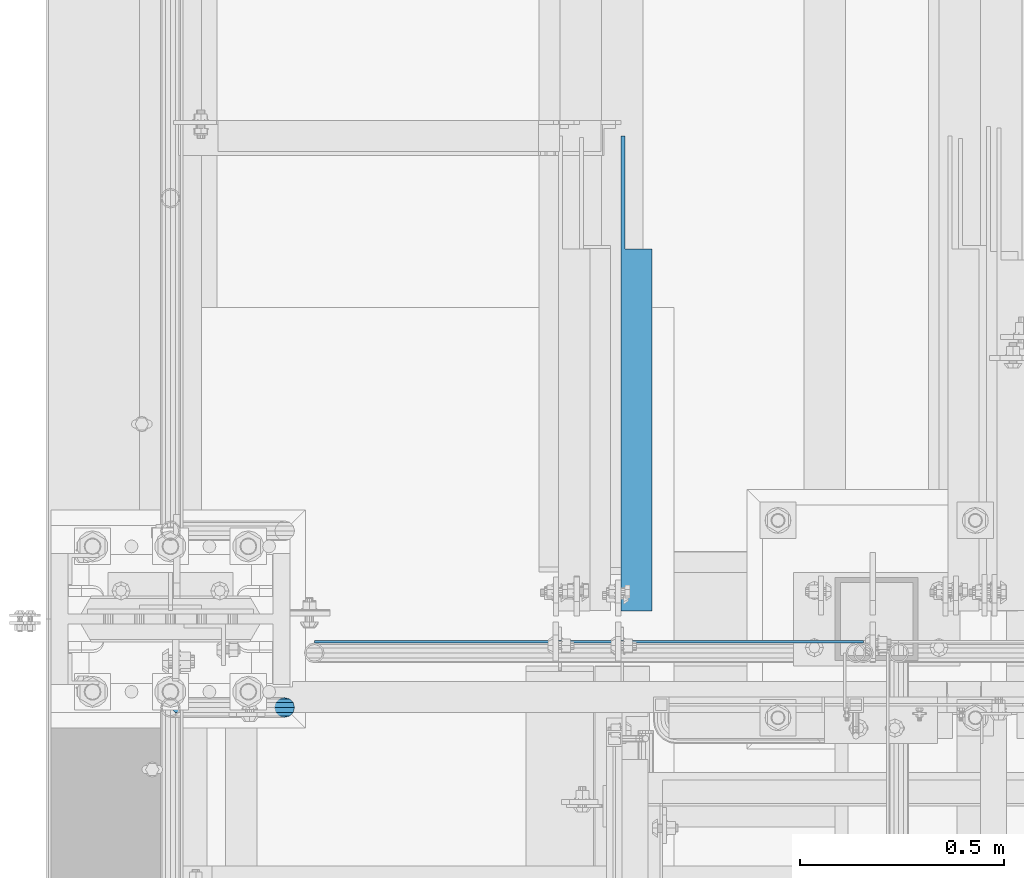
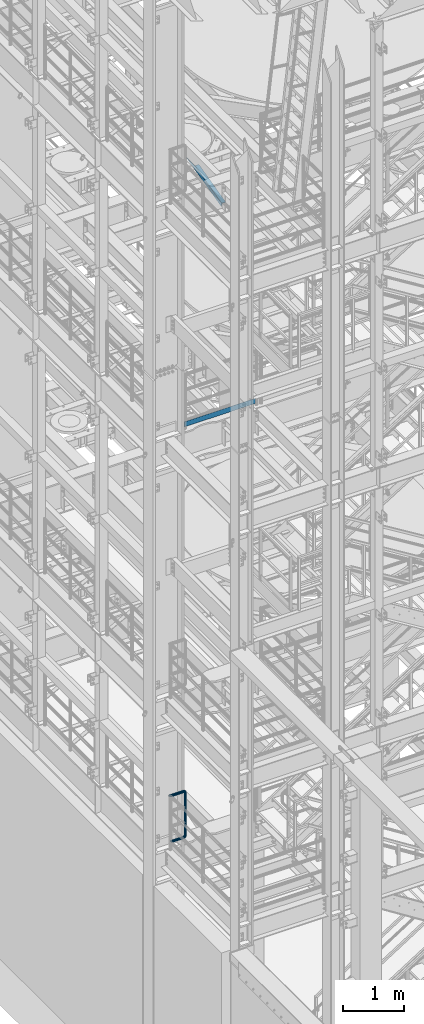
# One storey, part 962 of 1876: 3 beams, 3 elements without a shape of their own.
"""IFC2X3 building model written with IfcOpenShell, lengths in millimetres."""

from ifc_helpers import new_model, si_unit, frame, origin_with_axes, place, context, subcontext, project, spatial, faceted_brep, material, type_object, element, aggregate, save


model = new_model("IFC2X3")

# Units and contexts
model_context = context("Model", 3, precision=1e-05, world=origin_with_axes())
body_context = subcontext(model_context, "Body", "Model", "MODEL_VIEW")
ifc_project = project(units=[si_unit("LENGTHUNIT", "METRE", prefix="MILLI"), si_unit("AREAUNIT", "SQUARE_METRE"), si_unit("VOLUMEUNIT", "CUBIC_METRE"), si_unit("MASSUNIT", "GRAM", prefix="KILO"), si_unit("TIMEUNIT", "SECOND"), si_unit("PLANEANGLEUNIT", "RADIAN"), si_unit("SOLIDANGLEUNIT", "STERADIAN"), si_unit("THERMODYNAMICTEMPERATUREUNIT", "DEGREE_CELSIUS"), si_unit("LUMINOUSINTENSITYUNIT", "LUMEN")], contexts=[model_context])

# Site, building, storey
site_placement = place(None, origin_with_axes())
site = spatial("IfcSite", under=ifc_project, at=site_placement, CompositionType="ELEMENT")
building_placement = place(site_placement, origin_with_axes())
building = spatial("IfcBuilding", under=site, at=building_placement, Name="Undefined", CompositionType="ELEMENT")
storey_placement = place(building_placement, origin_with_axes())
storey = spatial("IfcBuildingStorey", under=building, at=storey_placement, Name="Undefined", CompositionType="ELEMENT", Elevation=0.0)

# Assembly, beam
assembly_1_placement = place(storey_placement, origin_with_axes())
assembly_1 = element("IfcElementAssembly", 1, at=assembly_1_placement, inside=storey, Name="RAIL", AssemblyPlace="NOTDEFINED", PredefinedType="RIGID_FRAME")
ifc_material_1 = material()
beam_type_1 = type_object("IfcBeamType", Name="PIPE1-1/2SCH40", PredefinedType="NOTDEFINED")
beam_1_placement = place(assembly_1_placement, frame((5.00222085975111e-12, -4788.2175, 6207.125), z_axis=(0.0, 0.0, 1.0), x_axis=(1.0, 0.0, 0.0)))
beam_1 = element("IfcBeam", 2, at=beam_1_placement, type_object=beam_type_1, material=ifc_material_1, Name="RAIL", ObjectType="PIPE1-1/2SCH40", context=body_context, shape_type="Brep", body=[
    faceted_brep([(1.20714750983051e-12, 24.1299999999974, -914.399963378906), (12.0650000000014, 20.8971929933159, -926.464963378905), (12.0650000000014, 20.8971929933177, -902.334963378908), (12.0650000000014, -20.8971929933195, -902.334963378908), (12.0650000000014, -20.8971929933195, -926.464963378905), (1.52133659548828e-12, -24.130000000001, -914.399963378906), (20.8971929933199, -12.0650000000023, -893.502770385589), (20.8971929933199, -12.0650000000005, -898.533841947723), (15.2545715621378, -17.7076214311819, -904.176463378906), (12.5151929933181, -20.4470000000019, -914.399963378906), (15.2545715621376, -17.7076214311819, -924.623463378906), (20.8971929933199, -12.0650000000005, -930.26608481009), (20.8971929933199, -12.0650000000023, -935.297156372224), (24.1300000000014, -1.81898940354586e-12, -934.846963378906), (24.1300000000014, -1.81898940354586e-12, -938.529963378907), (21.3906214311813, -10.2235000000019, -932.107584810088), (21.3906214311823, 10.2234999999982, -932.107584810088), (20.8971929933199, 12.0650000000005, -930.266084810086), (20.8971929933199, 12.0649999999987, -935.297156372224), (15.2545715621413, 17.7076214311783, -924.623463378906), (12.5151929933216, 20.4469999999983, -914.399963378906), (15.2545715621411, 17.7076214311783, -904.176463378906), (20.8971929933199, 12.0650000000005, -898.533841947727), (20.8971929933199, 12.0649999999987, -893.502770385589), (21.3906214311822, 10.2234999999982, -896.692341947724), (24.1300000000014, 0.0, -893.952963378906), (24.1300000000014, 0.0, -890.269963378905), (21.3906214311814, -10.2235000000019, -896.692341947724), (241.299995422363, -20.8971929933177, 12.0649999999987), (241.299995422363, -24.1299999999992, 0.0), (253.073542436527, -24.1299999999992, -1.86474665447167), (256.801832473661, -20.8971929933177, 9.60975021462946), (241.299995422363, -12.0650000000005, 20.8971929933177), (259.531130206197, -12.0650000000005, 18.0096649141014), (241.299995422363, 0.0, 24.130000000001), (260.530122510796, 0.0, 21.084247083727), (241.299995422363, 12.0650000000005, 20.8971929933177), (259.531130206197, 12.0650000000005, 18.0096649141014), (241.299995422363, 20.8971929933177, 12.0649999999987), (256.801832473661, 20.8971929933177, 9.60975021462946), (241.299995422363, 24.1299999999992, 0.0), (253.073542436527, 24.1299999999992, -1.86474665447167), (241.299995422363, 20.8971929933177, -12.0649999999987), (249.345252399393, 20.8971929933177, -13.3392435235728), (241.299995422363, 12.0650000000005, -20.8971929933177), (246.615954666858, 12.0650000000005, -21.7391582230448), (241.299995422363, 0.0, -24.130000000001), (245.616962362259, 0.0, -24.8137403926739), (241.299995422363, -12.0650000000005, -20.8971929933177), (246.615954666858, -12.0650000000005, -21.7391582230448), (241.299995422363, -20.8971929933177, -12.0649999999987), (249.345252399393, -20.8971929933177, -13.3392435235728), (267.334993896485, 20.8971929933177, -38.0999984741211), (279.399993896485, 24.1299999999992, -38.0999984741211), (279.399993896484, 24.1299999999992, -876.299964904785), (267.334993896484, 20.8971929933177, -876.299964904785), (291.464993896486, 20.8971929933177, -38.0999984741211), (291.464993896484, 20.8971929933177, -876.299964904785), (300.297186889804, 12.0650000000005, -38.0999984741211), (300.297186889803, 12.0650000000005, -876.299964904785), (303.529993896486, 0.0, -38.0999984741211), (303.529993896484, 0.0, -876.299964904785), (300.297186889804, -12.0650000000005, -38.0999984741211), (300.297186889803, -12.0650000000005, -876.299964904785), (291.464993896486, -20.8971929933177, -38.0999984741211), (291.464993896484, -20.8971929933177, -876.299964904785), (279.399993896484, -24.1299999999992, -38.0999984741211), (279.399993896484, -24.1299999999992, -876.299964904785), (267.334993896485, -20.8971929933177, -38.0999984741211), (267.334993896484, -20.8971929933177, -876.299964904785), (258.502800903167, -12.0650000000005, -38.0999984741211), (258.502800903166, -12.0650000000005, -876.299964904785), (255.269993896485, 0.0, -38.0999984741211), (255.269993896484, 0.0, -876.299964904785), (258.502800903167, 12.0650000000005, -38.0999984741211), (258.502800903166, 12.0650000000005, -876.299964904785), (257.660835673438, 12.0650000000005, -881.615924149282), (254.586253503809, 0.0, -880.616931844681), (257.660835673438, -12.0650000000005, -881.615924149282), (266.06075037291, -20.8971929933177, -884.345221881817), (277.535247242011, -24.130000000001, -888.073511918952), (289.009744111112, -20.8971929933195, -891.801801956084), (297.409658810584, -12.0650000000005, -894.531099688622), (300.484240980214, 0.0, -895.53009199322), (297.409658810584, 12.0650000000005, -894.531099688622), (289.009744111112, 20.8971929933177, -891.801801956084), (277.535247242011, 24.1299999999992, -888.073511918952), (266.06075037291, 20.8971929933177, -884.345221881817), (241.299995422364, -1.81898940354586e-12, -938.529963378911), (241.299995422364, -12.0650000000005, -935.297156372228), (241.299995422364, -20.8971929933195, -926.464963378909), (241.299995422363, -24.130000000001, -914.399963378906), (241.299995422363, -20.8971929933195, -902.334963378908), (241.299995422363, -12.0650000000005, -893.502770385589), (241.299995422363, 0.0, -890.269963378909), (241.299995422364, 20.8971929933177, -926.464963378909), (241.299995422364, 12.0649999999987, -935.297156372228), (241.299995422364, 24.1299999999992, -914.39996337891), (241.299995422363, 20.8971929933177, -902.334963378908), (241.299995422363, 12.0649999999987, -893.502770385589), (260.530122510801, 0.0, -935.484210462637), (259.531130206202, 12.0649999999987, -932.409628293008), (259.531130206201, -12.0650000000005, -932.409628293008), (256.801832473666, -20.8971929933195, -924.009713593536), (253.07354243653, -24.130000000001, -912.535216724435), (249.345252399395, -20.8971929933195, -901.060719855333), (246.615954666859, -12.0650000000005, -892.660805155861), (245.61696236226, 0.0, -889.586222986232), (246.615954666859, 12.0649999999987, -892.660805155861), (249.345252399395, 20.8971929933177, -901.060719855333), (253.07354243653, 24.1299999999992, -912.535216724435), (256.801832473666, 20.8971929933177, -924.009713593536), (275.977674493594, 12.0649999999987, -924.029695422345), (270.786241706733, 20.8971929933177, -916.884301193139), (277.877870775644, 0.0, -926.645091230272), (275.977674493608, -12.0650000000005, -924.029695422334), (270.786241706733, -20.8971929933195, -916.884301193139), (263.694612637823, -24.130000000001, -907.123511156005), (256.602983568912, -20.8971929933195, -897.362721118872), (251.411550782037, -12.0650000000005, -890.21732688968), (249.511354500001, 0.0, -887.601931081743), (251.411550782037, 12.0650000000005, -890.21732688968), (256.602983568912, 20.8971929933177, -897.362721118872), (263.694612637823, 24.1299999999992, -907.123511156005), (281.884331710718, 20.8971929933177, -905.786211189152), (272.123541673585, 24.1299999999992, -898.694582120243), (289.029725939912, 12.0650000000005, -910.977643976028), (291.645121747852, 0.0, -912.877840258065), (289.029725939912, -12.0650000000005, -910.977643976028), (281.884331710718, -20.8971929933195, -905.786211189152), (272.123541673585, -24.130000000001, -898.694582120243), (262.362751636451, -20.8971929933195, -891.602953051333), (255.217357407258, -12.0650000000005, -886.411520264461), (252.601961599318, 0.0, -884.511323982424), (255.217357407258, 12.0650000000005, -886.411520264461), (262.362751636451, 20.8971929933177, -891.602953051333), (266.060750372911, 20.8971929933177, -30.0547414970897), (257.660835673439, 12.0650000000005, -32.7840392296275), (277.535247242011, 24.1299999999992, -26.3264514599541), (289.009744111112, 20.8971929933177, -22.5981614228222), (297.409658810584, 12.0650000000005, -19.8688636902843), (300.484240980213, 0.0, -18.8698713856866), (297.409658810584, -12.0650000000005, -19.8688636902843), (289.009744111112, -20.8971929933177, -22.5981614228222), (277.535247242011, -24.1299999999992, -26.3264514599541), (266.060750372911, -20.8971929933177, -30.0547414970897), (257.660835673439, -12.0650000000005, -32.7840392296275), (254.58625350381, 0.0, -33.7830315342253), (255.217357407257, 12.0650000000005, -27.9884431144455), (252.601961599318, 0.0, -29.8886393964822), (262.362751636451, 20.8971929933177, -22.7970103275729), (272.123541673583, 24.1299999999992, -15.7053812586601), (281.884331710716, 20.8971929933177, -8.61375218975081), (289.029725939909, 12.0650000000005, -3.42231940287456), (291.645121747848, 0.0, -1.52212312084157), (289.029725939909, -12.0650000000005, -3.42231940287456), (281.884331710716, -20.8971929933177, -8.61375218975081), (272.123541673583, -24.1299999999992, -15.7053812586601), (262.362751636451, -20.8971929933177, -22.7970103275729), (255.217357407257, -12.0650000000005, -27.9884431144455), (249.511354500002, 0.0, -26.7980322971671), (251.411550782037, -12.0650000000005, -24.1826364892258), (251.411550782037, 12.0650000000005, -24.1826364892258), (256.602983568912, 20.8971929933177, -17.037242260034), (263.694612637822, 24.1299999999992, -7.27645222290084), (270.786241706732, 20.8971929933177, 2.48433781423228), (275.977674493607, 12.0650000000005, 9.62973204342416), (277.877870775642, 0.0, 12.2451278513654), (275.977674493607, -12.0650000000005, 9.62973204342416), (270.786241706732, -20.8971929933177, 2.48433781423228), (263.694612637822, -24.1299999999992, -7.27645222290084), (256.602983568912, -20.8971929933177, -17.037242260034), (24.1299999999854, -24.1299999999992, 0.0), (20.8971929933039, -20.8971929933177, -12.0649999999987), (12.0649999999854, -12.0650000000005, -20.8971929933177), (20.8971929933249, -12.0650000000005, -20.8971929933177), (16.4810997545745, -16.4810997545883, -16.48109323873), (24.1300000000063, 0.0, -24.130000000001), (-1.45519152283669e-11, 0.0, -24.130000000001), (20.8971929933249, 12.0650000000005, -20.8971929933177), (-12.0650000000145, 12.0650000000005, -20.8971929933177), (-20.897192993333, 20.8971929933177, -12.0649999999987), (-12.0649999999986, 20.8971929933177, -12.0649999999987), (12.0650000000064, 20.8971929933177, -12.0649999999987), (-16.481093238746, 16.4810932387318, -16.4810997545865), (0.0, 24.1299999999992, 0.0), (-24.1300000000145, 24.1299999999992, 0.0), (-20.897192993333, 20.8971929933177, 12.0649999999987), (-12.0650000000145, 12.0650000000005, 20.8971929933177), (-1.45519152283669e-11, 0.0, 24.130000000001), (12.0649999999854, -12.0650000000005, 20.8971929933177), (20.8971929933039, -20.8971929933177, 12.0649999999987), (241.299995422363, -17.7076214311801, 10.2235000000001), (241.299995422363, -20.4470000000001, 0.0), (20.4469999999854, -20.4470000000001, 0.0), (17.7076214311658, -17.7076214311801, 10.2235000000001), (241.299995422363, 0.0, 20.4470000000001), (241.299995422363, -10.2235000000001, 17.7076214311819), (10.2234999999854, -10.2235000000001, 17.7076214311819), (-1.45519152283669e-11, 0.0, 20.4470000000001), (241.299995422363, 10.2235000000001, 17.7076214311819), (-10.2235000000145, 10.2235000000001, 17.7076214311819), (241.299995422363, 17.7076214311801, 10.2235000000001), (-17.7076214311949, 17.7076214311801, 10.2235000000001), (241.299995422363, 20.4470000000001, 0.0), (-20.4470000000145, 20.4470000000001, 0.0), (241.299995422363, 17.7076214311801, -10.2235000000001), (-17.7076214311949, 17.7076214311801, -10.2235000000001), (241.299995422363, 10.2235000000001, -17.7076214311819), (-10.2235000000145, 10.2235000000001, -17.7076214311819), (241.299995422363, 0.0, -20.4470000000001), (-1.45519152283669e-11, 0.0, -20.4470000000001), (241.299995422363, -10.2235000000001, -17.7076214311819), (10.2234999999854, -10.2235000000001, -17.7076214311819), (241.299995422363, -17.7076214311801, -10.2235000000001), (17.7076214311658, -17.7076214311801, -10.2235000000001), (258.545498388721, -10.2235000000001, 14.9762020957387), (256.23277767852, -17.7076214311801, 7.85837963987069), (253.073542436527, -20.4470000000001, -1.86474665447167), (249.914307194535, -17.7076214311801, -11.5878729488177), (247.601586484334, -10.2235000000001, -18.7056954046857), (246.755071952542, 0.0, -21.31099924316), (247.601586484334, 10.2235000000001, -18.7056954046857), (249.914307194535, 17.7076214311801, -11.5878729488177), (253.073542436527, 20.4470000000001, -1.86474665447167), (256.23277767852, 17.7076214311801, 7.85837963987069), (258.545498388721, 10.2235000000001, 14.9762020957387), (259.392012920513, 0.0, 17.5815059342131), (275.713057691449, 0.0, 9.26551826108334), (274.10289136825, -10.2235000000001, 7.04931444488102), (274.10289136825, 10.2235000000001, 7.04931444488102), (269.703835164635, 17.7076214311801, 0.994533019089431), (263.694612637822, 20.4470000000001, -7.27645222290084), (257.685390111009, 17.7076214311801, -15.5474374648911), (253.286333907394, 10.2235000000001, -21.6022188906827), (251.676167584195, 0.0, -23.818422706885), (253.286333907394, -10.2235000000001, -21.6022188906827), (257.685390111009, -17.7076214311801, -15.5474374648911), (263.694612637822, -20.4470000000001, -7.27645222290084), (269.703835164635, -17.7076214311801, 0.994533019089431), (286.449308341364, -10.2235000000001, -5.29710252823133), (280.394526915574, -17.7076214311801, -9.69615873184739), (288.665512157566, 0.0, -3.68693620503473), (286.449308341364, 10.2235000000001, -5.29710252823133), (280.394526915574, 17.7076214311801, -9.69615873184739), (272.123541673583, 20.4470000000001, -15.7053812586601), (263.852556431592, 17.7076214311801, -21.7146037854764), (257.797775005802, 10.2235000000001, -26.1136599890888), (255.581571189601, 0.0, -27.723826312289), (257.797775005802, -10.2235000000001, -26.1136599890888), (263.852556431592, -17.7076214311801, -21.7146037854764), (272.123541673583, -20.4470000000001, -15.7053812586601), (287.258373536355, -17.7076214311801, -23.1672162179639), (277.535247242011, -20.4470000000001, -26.3264514599541), (294.376195992223, -10.2235000000001, -20.8544955077632), (296.981499830698, 0.0, -20.00798097597), (294.376195992223, 10.2235000000001, -20.8544955077632), (287.258373536355, 17.7076214311801, -23.1672162179639), (277.535247242011, 20.4470000000001, -26.3264514599541), (267.812120947668, 17.7076214311801, -29.485686701948), (260.6942984918, 10.2235000000001, -31.7984074121487), (258.088994653325, 0.0, -32.6449219439419), (260.6942984918, -10.2235000000001, -31.7984074121487), (267.812120947668, -17.7076214311801, -29.485686701948), (279.399993896484, -20.4470000000001, -38.0999984741211), (269.176493896485, -17.7076214311801, -38.0999984741211), (289.623493896486, -17.7076214311801, -38.0999984741211), (297.107615327666, -10.2235000000001, -38.0999984741211), (299.846993896486, 0.0, -38.0999984741211), (297.107615327666, 10.2235000000001, -38.0999984741211), (289.623493896486, 17.7076214311801, -38.0999984741211), (279.399993896485, 20.4470000000001, -38.0999984741211), (269.176493896485, 17.7076214311801, -38.0999984741211), (261.692372465305, 10.2235000000001, -38.0999984741211), (258.952993896485, 0.0, -38.0999984741211), (261.692372465305, -10.2235000000001, -38.0999984741211), (269.176493896484, -17.7076214311801, -876.299964904785), (261.692372465304, -10.2235000000001, -876.299964904785), (258.952993896484, 0.0, -876.299964904785), (261.692372465304, 10.2235000000001, -876.299964904785), (269.176493896484, 17.7076214311801, -876.299964904785), (279.399993896484, 20.4470000000001, -876.299964904785), (289.623493896484, 17.7076214311801, -876.299964904785), (297.107615327665, 10.2235000000001, -876.299964904785), (299.846993896484, 0.0, -876.299964904785), (297.107615327665, -10.2235000000001, -876.299964904785), (289.623493896484, -17.7076214311801, -876.299964904785), (279.399993896484, -20.4470000000001, -876.299964904785), (277.535247242011, -20.4470000000001, -888.073511918952), (267.812120947667, -17.7076214311801, -884.914276676958), (260.694298491799, -10.2235000000001, -882.601555966758), (258.088994653324, 0.0, -881.755041434964), (260.694298491799, 10.2235000000001, -882.601555966758), (267.812120947668, 17.7076214311801, -884.914276676958), (277.535247242011, 20.4470000000001, -888.073511918952), (287.258373536355, 17.7076214311801, -891.232747160942), (294.376195992223, 10.2235000000001, -893.545467871143), (296.981499830699, 0.0, -894.391982402936), (294.376195992223, -10.2235000000001, -893.545467871143), (287.258373536355, -17.7076214311801, -891.232747160942), (280.394526915577, -17.7076214311801, -904.703804647055), (272.123541673585, -20.4470000000001, -898.694582120243), (286.449308341367, -10.2235000000001, -909.102860850671), (288.665512157569, 0.0, -910.713027173868), (286.449308341367, 10.2235000000001, -909.102860850671), (280.394526915577, 17.7076214311801, -904.703804647055), (272.123541673585, 20.4470000000001, -898.694582120243), (263.852556431593, 17.7076214311801, -892.68535959343), (257.797775005802, 10.2235000000001, -888.286303389817), (255.581571189601, 0.0, -886.676137066617), (257.797775005802, -10.2235000000001, -888.286303389817), (263.852556431593, -17.7076214311801, -892.68535959343), (263.694612637823, -20.4470000000001, -907.123511156005), (257.685390111009, -17.7076214311801, -898.852525914015), (269.703835164636, -17.7076214311801, -915.394496397999), (274.102891368238, -10.2235000000001, -921.449277823798), (275.71305769145, 0.0, -923.66548163999), (274.102891368251, 10.2235000000001, -921.449277823787), (269.703835164636, 17.7076214311801, -915.394496397999), (263.694612637823, 20.4470000000001, -907.123511156005), (257.685390111009, 17.7076214311801, -898.852525914015), (253.286333907394, 10.2235000000001, -892.797744488227), (251.676167584195, 0.0, -890.581540672025), (253.286333907394, -10.2235000000001, -892.797744488227), (249.914307194537, -17.7076214311801, -902.812090430092), (247.601586484335, -10.2235000000001, -895.694267974224), (253.07354243653, -20.4470000000001, -912.535216724435), (256.232777678524, -17.7076214311819, -922.258343018777), (258.545498388725, -10.2235000000001, -929.376165474645), (259.392012920517, 0.0, -931.981469313119), (258.545498388725, 10.2235000000001, -929.376165474645), (256.232777678524, 17.7076214311801, -922.258343018777), (253.07354243653, 20.4470000000001, -912.535216724435), (249.914307194537, 17.7076214311801, -902.812090430092), (247.601586484335, 10.2235000000001, -895.694267974224), (246.755071952543, 0.0, -893.088964135746), (241.299995422363, -10.2235000000001, -896.692341947728), (241.299995422363, 0.0, -893.95296337891), (241.299995422363, -17.7076214311819, -904.17646337891), (241.299995422363, -20.4470000000001, -914.399963378906), (241.299995422364, -17.7076214311819, -924.62346337891), (241.299995422364, -10.2235000000001, -932.107584810088), (241.299995422364, -1.81898940354586e-12, -934.84696337891), (241.299995422364, 10.2234999999982, -932.107584810088), (241.299995422364, 17.7076214311801, -924.62346337891), (241.299995422364, 20.4470000000001, -914.39996337891), (241.299995422363, 17.7076214311801, -904.17646337891), (241.299995422363, 10.2235000000001, -896.692341947728)], [[[0, 1, 2]], [[3, 4, 5]], [[6, 7, 8, 9, 10, 11, 12, 4, 3]], [[13, 14, 12, 11, 15]], [[16, 17, 18, 14, 13]], [[2, 1, 18, 17, 19, 20, 21, 22, 23]], [[23, 22, 24, 25, 26]], [[26, 25, 27, 7, 6]], [[28, 29, 30, 31]], [[32, 28, 31, 33]], [[34, 32, 33, 35]], [[36, 34, 35, 37]], [[38, 36, 37, 39]], [[40, 38, 39, 41]], [[42, 40, 41, 43]], [[44, 42, 43, 45]], [[46, 44, 45, 47]], [[48, 46, 47, 49]], [[50, 48, 49, 51]], [[52, 53, 54, 55]], [[53, 56, 57, 54]], [[56, 58, 59, 57]], [[58, 60, 61, 59]], [[60, 62, 63, 61]], [[62, 64, 65, 63]], [[64, 66, 67, 65]], [[66, 68, 69, 67]], [[68, 70, 71, 69]], [[70, 72, 73, 71]], [[72, 74, 75, 73]], [[73, 75, 76, 77]], [[71, 73, 77, 78]], [[69, 71, 78, 79]], [[67, 69, 79, 80]], [[65, 67, 80, 81]], [[63, 65, 81, 82]], [[61, 63, 82, 83]], [[59, 61, 83, 84]], [[57, 59, 84, 85]], [[54, 57, 85, 86]], [[55, 54, 86, 87]], [[88, 89, 12, 14]], [[89, 90, 4, 12]], [[90, 91, 5, 4]], [[91, 92, 3, 5]], [[92, 93, 6, 3]], [[93, 94, 26, 6]], [[95, 96, 18, 1]], [[97, 95, 1, 0]], [[98, 97, 0, 2]], [[99, 98, 2, 23]], [[94, 99, 23, 26]], [[96, 88, 14, 18]], [[100, 88, 96, 101]], [[102, 89, 88, 100]], [[103, 90, 89, 102]], [[104, 91, 90, 103]], [[105, 92, 91, 104]], [[106, 93, 92, 105]], [[107, 94, 93, 106]], [[108, 99, 94, 107]], [[109, 98, 99, 108]], [[110, 97, 98, 109]], [[111, 95, 97, 110]], [[101, 96, 95, 111]], [[112, 101, 111, 113]], [[114, 100, 101, 112]], [[115, 102, 100, 114]], [[116, 103, 102, 115]], [[117, 104, 103, 116]], [[118, 105, 104, 117]], [[119, 106, 105, 118]], [[120, 107, 106, 119]], [[121, 108, 107, 120]], [[122, 109, 108, 121]], [[123, 110, 109, 122]], [[113, 111, 110, 123]], [[124, 113, 123, 125]], [[126, 112, 113, 124]], [[127, 114, 112, 126]], [[128, 115, 114, 127]], [[129, 116, 115, 128]], [[130, 117, 116, 129]], [[131, 118, 117, 130]], [[132, 119, 118, 131]], [[133, 120, 119, 132]], [[134, 121, 120, 133]], [[135, 122, 121, 134]], [[125, 123, 122, 135]], [[86, 125, 135, 87]], [[85, 124, 125, 86]], [[84, 126, 124, 85]], [[83, 127, 126, 84]], [[82, 128, 127, 83]], [[81, 129, 128, 82]], [[80, 130, 129, 81]], [[79, 131, 130, 80]], [[78, 132, 131, 79]], [[77, 133, 132, 78]], [[76, 134, 133, 77]], [[87, 135, 134, 76]], [[75, 55, 87, 76]], [[74, 52, 55, 75]], [[136, 52, 74, 137]], [[138, 53, 52, 136]], [[139, 56, 53, 138]], [[140, 58, 56, 139]], [[141, 60, 58, 140]], [[142, 62, 60, 141]], [[143, 64, 62, 142]], [[144, 66, 64, 143]], [[145, 68, 66, 144]], [[146, 70, 68, 145]], [[147, 72, 70, 146]], [[137, 74, 72, 147]], [[148, 137, 147, 149]], [[150, 136, 137, 148]], [[151, 138, 136, 150]], [[152, 139, 138, 151]], [[153, 140, 139, 152]], [[154, 141, 140, 153]], [[155, 142, 141, 154]], [[156, 143, 142, 155]], [[157, 144, 143, 156]], [[158, 145, 144, 157]], [[159, 146, 145, 158]], [[149, 147, 146, 159]], [[160, 149, 159, 161]], [[162, 148, 149, 160]], [[163, 150, 148, 162]], [[164, 151, 150, 163]], [[165, 152, 151, 164]], [[166, 153, 152, 165]], [[167, 154, 153, 166]], [[168, 155, 154, 167]], [[169, 156, 155, 168]], [[170, 157, 156, 169]], [[171, 158, 157, 170]], [[161, 159, 158, 171]], [[49, 161, 171, 51]], [[47, 160, 161, 49]], [[45, 162, 160, 47]], [[43, 163, 162, 45]], [[41, 164, 163, 43]], [[39, 165, 164, 41]], [[37, 166, 165, 39]], [[35, 167, 166, 37]], [[33, 168, 167, 35]], [[31, 169, 168, 33]], [[30, 170, 169, 31]], [[51, 171, 170, 30]], [[29, 50, 51, 30]], [[50, 29, 172, 173]], [[174, 175, 48, 50, 173, 176]], [[177, 46, 48, 175, 174, 178]], [[179, 44, 46, 177, 178, 180]], [[181, 182, 183, 42, 44, 179, 180, 184]], [[185, 40, 42, 183, 182, 181, 186]], [[38, 40, 185, 186, 187]], [[36, 38, 187, 188]], [[34, 36, 188, 189]], [[32, 34, 189, 190]], [[28, 32, 190, 191]], [[29, 28, 191, 172]], [[192, 193, 194, 195]], [[196, 197, 198, 199]], [[200, 196, 199, 201]], [[202, 200, 201, 203]], [[204, 202, 203, 205]], [[206, 204, 205, 207]], [[208, 206, 207, 209]], [[210, 208, 209, 211]], [[212, 210, 211, 213]], [[214, 212, 213, 215]], [[193, 214, 215, 194]], [[190, 189, 188, 187, 186, 181, 184, 180, 178, 174, 176, 173, 172, 191], [213, 211, 209, 207, 205, 203, 201, 199, 198, 195, 194, 215]], [[197, 192, 195, 198]], [[192, 197, 216, 217]], [[193, 192, 217, 218]], [[214, 193, 218, 219]], [[212, 214, 219, 220]], [[210, 212, 220, 221]], [[208, 210, 221, 222]], [[206, 208, 222, 223]], [[204, 206, 223, 224]], [[202, 204, 224, 225]], [[200, 202, 225, 226]], [[196, 200, 226, 227]], [[197, 196, 227, 216]], [[227, 228, 229, 216]], [[226, 230, 228, 227]], [[225, 231, 230, 226]], [[224, 232, 231, 225]], [[223, 233, 232, 224]], [[222, 234, 233, 223]], [[221, 235, 234, 222]], [[220, 236, 235, 221]], [[219, 237, 236, 220]], [[218, 238, 237, 219]], [[217, 239, 238, 218]], [[216, 229, 239, 217]], [[229, 240, 241, 239]], [[228, 242, 240, 229]], [[230, 243, 242, 228]], [[231, 244, 243, 230]], [[232, 245, 244, 231]], [[233, 246, 245, 232]], [[234, 247, 246, 233]], [[235, 248, 247, 234]], [[236, 249, 248, 235]], [[237, 250, 249, 236]], [[238, 251, 250, 237]], [[239, 241, 251, 238]], [[241, 252, 253, 251]], [[240, 254, 252, 241]], [[242, 255, 254, 240]], [[243, 256, 255, 242]], [[244, 257, 256, 243]], [[245, 258, 257, 244]], [[246, 259, 258, 245]], [[247, 260, 259, 246]], [[248, 261, 260, 247]], [[249, 262, 261, 248]], [[250, 263, 262, 249]], [[251, 253, 263, 250]], [[253, 264, 265, 263]], [[252, 266, 264, 253]], [[254, 267, 266, 252]], [[255, 268, 267, 254]], [[256, 269, 268, 255]], [[257, 270, 269, 256]], [[258, 271, 270, 257]], [[259, 272, 271, 258]], [[260, 273, 272, 259]], [[261, 274, 273, 260]], [[262, 275, 274, 261]], [[263, 265, 275, 262]], [[275, 265, 276, 277]], [[274, 275, 277, 278]], [[273, 274, 278, 279]], [[272, 273, 279, 280]], [[271, 272, 280, 281]], [[270, 271, 281, 282]], [[269, 270, 282, 283]], [[268, 269, 283, 284]], [[267, 268, 284, 285]], [[266, 267, 285, 286]], [[264, 266, 286, 287]], [[265, 264, 287, 276]], [[276, 287, 288, 289]], [[277, 276, 289, 290]], [[278, 277, 290, 291]], [[279, 278, 291, 292]], [[280, 279, 292, 293]], [[281, 280, 293, 294]], [[282, 281, 294, 295]], [[283, 282, 295, 296]], [[284, 283, 296, 297]], [[285, 284, 297, 298]], [[286, 285, 298, 299]], [[287, 286, 299, 288]], [[299, 300, 301, 288]], [[298, 302, 300, 299]], [[297, 303, 302, 298]], [[296, 304, 303, 297]], [[295, 305, 304, 296]], [[294, 306, 305, 295]], [[293, 307, 306, 294]], [[292, 308, 307, 293]], [[291, 309, 308, 292]], [[290, 310, 309, 291]], [[289, 311, 310, 290]], [[288, 301, 311, 289]], [[301, 312, 313, 311]], [[300, 314, 312, 301]], [[302, 315, 314, 300]], [[303, 316, 315, 302]], [[304, 317, 316, 303]], [[305, 318, 317, 304]], [[306, 319, 318, 305]], [[307, 320, 319, 306]], [[308, 321, 320, 307]], [[309, 322, 321, 308]], [[310, 323, 322, 309]], [[311, 313, 323, 310]], [[313, 324, 325, 323]], [[312, 326, 324, 313]], [[314, 327, 326, 312]], [[315, 328, 327, 314]], [[316, 329, 328, 315]], [[317, 330, 329, 316]], [[318, 331, 330, 317]], [[319, 332, 331, 318]], [[320, 333, 332, 319]], [[321, 334, 333, 320]], [[322, 335, 334, 321]], [[323, 325, 335, 322]], [[325, 336, 337, 335]], [[324, 338, 336, 325]], [[326, 339, 338, 324]], [[327, 340, 339, 326]], [[328, 341, 340, 327]], [[329, 342, 341, 328]], [[330, 343, 342, 329]], [[331, 344, 343, 330]], [[332, 345, 344, 331]], [[333, 346, 345, 332]], [[334, 347, 346, 333]], [[335, 337, 347, 334]], [[347, 337, 25, 24]], [[21, 346, 347, 24, 22]], [[345, 346, 21, 20]], [[344, 345, 20, 19]], [[343, 344, 19, 17, 16]], [[342, 343, 16, 13]], [[341, 342, 13, 15]], [[10, 340, 341, 15, 11]], [[339, 340, 10, 9]], [[338, 339, 9, 8]], [[336, 338, 8, 7, 27]], [[337, 336, 27, 25]]]),
])
aggregate(assembly_1, [beam_1])

assembly_2_placement = place(storey_placement, origin_with_axes())
assembly_2 = element("IfcElementAssembly", 3, at=assembly_2_placement, inside=storey, Name="RAIL", AssemblyPlace="NOTDEFINED", PredefinedType="RIGID_FRAME")
ifc_material_2 = material(Name="STEEL/A36")
beam_type_2 = type_object("IfcBeamType", PredefinedType="NOTDEFINED")
beam_2_placement = place(assembly_2_placement, frame((351.789999999997, -4627.56250114554, 13376.275), z_axis=(0.0, 0.0, 1.0), x_axis=(1.0, 0.0, 0.0)))
beam_2 = element("IfcBeam", 4, at=beam_2_placement, type_object=beam_type_2, material=ifc_material_2, Name="PLATE", context=body_context, shape_type="Brep", body=[
    faceted_brep([(0.0, 3.17500000000018, -50.8000000000002), (0.0, 3.17500000000018, 50.8000000000002), (1343.025, 3.17500000000018, 50.8000000000002), (1343.025, 3.17500000000018, -50.8000000000002), (0.0, -3.17500000000018, 50.8000000000002), (1343.025, -3.17500000000018, 50.8000000000002), (0.0, -3.17500000000018, -50.8000000000002), (1343.025, -3.17500000000018, -50.8000000000002)], [[[0, 1, 2, 3]], [[1, 4, 5, 2]], [[4, 6, 7, 5]], [[6, 0, 3, 7]], [[5, 7, 3, 2]], [[6, 4, 1, 0]]]),
])
aggregate(assembly_2, [beam_2])

assembly_3_placement = place(storey_placement, origin_with_axes())
assembly_3 = element("IfcElementAssembly", 5, at=assembly_3_placement, inside=storey, AssemblyPlace="NOTDEFINED", PredefinedType="RIGID_FRAME")
beam_type_3 = type_object("IfcBeamType", Name="L3X3X3/8", PredefinedType="NOTDEFINED")
beam_3_placement = place(assembly_3_placement, frame((1139.82500034226, -4562.7828185031, 17423.9442221814), z_axis=(1.0, 0.0, 0.0), x_axis=(0.0, 0.97029600569138, 0.241920774923019)))
beam_3 = element("IfcBeam", 6, at=beam_3_placement, type_object=beam_type_3, material=ifc_material_2, ObjectType="L3X3X3/8", context=body_context, shape_type="Brep", body=[
    faceted_brep([(20.4512332895073, 38.1000000000495, -38.0999999999999), (20.4512332895073, 38.1000000000495, 38.0999999999999), (892.440924395522, 38.0999999997366, 38.0999999999999), (892.440924395522, 38.0999999997366, -38.0999999999999), (20.4512332895037, 28.5750000000371, 38.0999999999999), (930.643800759319, 28.5749999997061, 38.0999999999999), (20.4512332895037, 28.5750000000371, -28.575), (930.643800759319, 28.5749999997061, -28.575), (20.4512332894728, -38.1000000000604, -28.575), (1198.0639353059, -38.1000000004824, -28.575), (20.4512332894728, -38.1000000000604, -38.0999999999999), (1198.0639353059, -38.1000000004824, -38.0999999999999)], [[[0, 1, 2, 3]], [[1, 4, 5, 2]], [[4, 6, 7, 5]], [[6, 8, 9, 7]], [[8, 10, 11, 9]], [[10, 0, 3, 11]], [[5, 7, 9, 11, 3, 2]], [[10, 8, 6, 4, 1, 0]]]),
])
aggregate(assembly_3, [beam_3])

save(model, "model.ifc")
